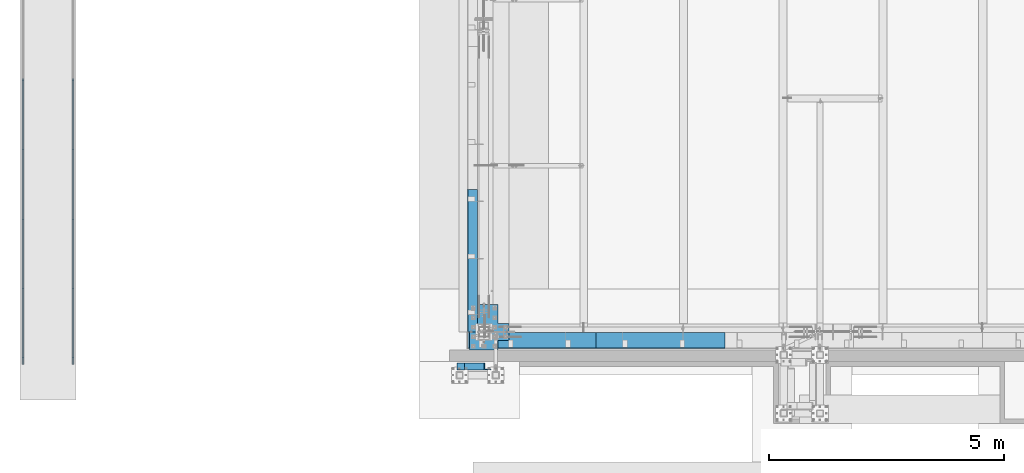
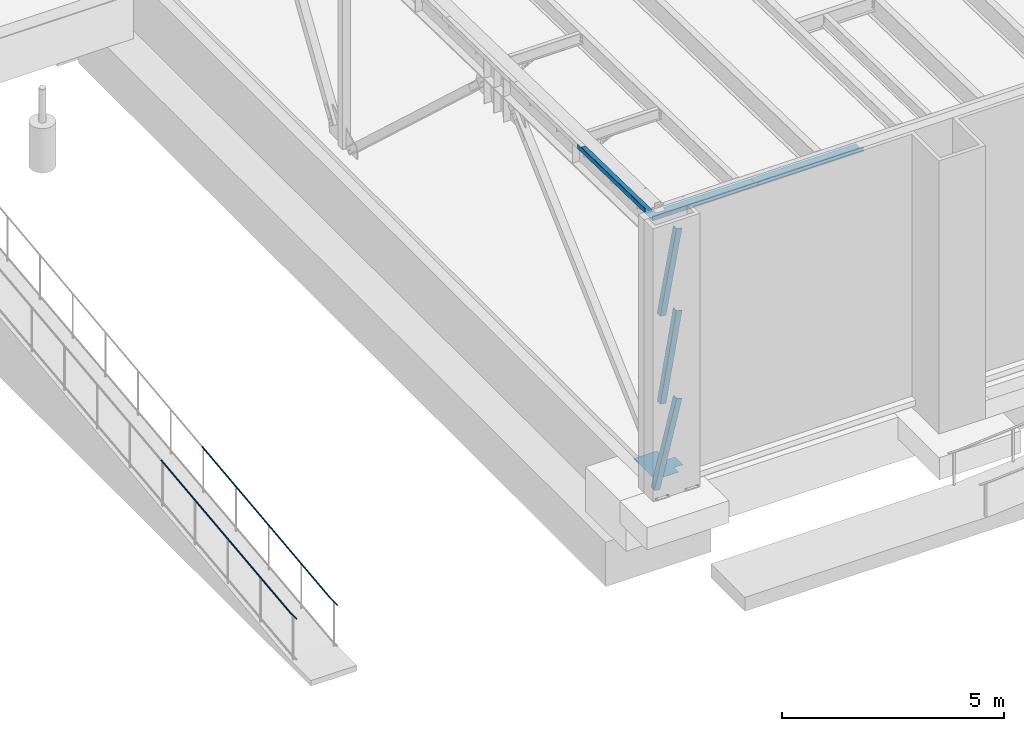
# One storey, part 1032 of 1763: 6 beams, 3 members, 6 elements without a shape of their own.
"""IFC2X3 building model written with IfcOpenShell, lengths in millimetres."""

from ifc_helpers import new_model, si_unit, frame, origin_with_axes, place, context, subcontext, project, spatial, faceted_brep, material, type_object, element, aggregate, save


model = new_model("IFC2X3")

# Units and contexts
model_context = context("Model", 3, precision=1e-05, world=origin_with_axes())
body_context = subcontext(model_context, "Body", "Model", "MODEL_VIEW")
ifc_project = project(units=[si_unit("LENGTHUNIT", "METRE", prefix="MILLI"), si_unit("AREAUNIT", "SQUARE_METRE"), si_unit("VOLUMEUNIT", "CUBIC_METRE"), si_unit("MASSUNIT", "GRAM", prefix="KILO"), si_unit("TIMEUNIT", "SECOND"), si_unit("PLANEANGLEUNIT", "RADIAN"), si_unit("SOLIDANGLEUNIT", "STERADIAN"), si_unit("THERMODYNAMICTEMPERATUREUNIT", "DEGREE_CELSIUS"), si_unit("LUMINOUSINTENSITYUNIT", "LUMEN")], contexts=[model_context])

# Site, building, storey
site_placement = place(None, origin_with_axes())
site = spatial("IfcSite", under=ifc_project, at=site_placement, CompositionType="ELEMENT")
building_placement = place(site_placement, origin_with_axes())
building = spatial("IfcBuilding", under=site, at=building_placement, Name="Undefined", CompositionType="ELEMENT")
storey_placement = place(building_placement, origin_with_axes())
storey = spatial("IfcBuildingStorey", under=building, at=storey_placement, Name="Undefined", CompositionType="ELEMENT", Elevation=0.0)

# Assembly, beam
assembly_1_placement = place(storey_placement, origin_with_axes())
assembly_1 = element("IfcElementAssembly", 1, at=assembly_1_placement, inside=storey, Name="GUARDRAIL", AssemblyPlace="NOTDEFINED", PredefinedType="RIGID_FRAME")
ifc_material_1 = material(Name="STEEL/A513")
beam_type_1 = type_object("IfcBeamType", PredefinedType="NOTDEFINED")
beam_1_placement = place(assembly_1_placement, frame((-97200.6527017878, -8312.29390356327, 5446.44809051835), z_axis=(1.0, 0.0, 0.0), x_axis=(0.0, -0.993473565260443, -0.114062593029902)))
beam_1 = element("IfcBeam", 2, at=beam_1_placement, type_object=beam_type_1, material=ifc_material_1, Name="GUARDRAIL", context=body_context, shape_type="Brep", body=[
    faceted_brep([(0.0, -19.0500000000029, 0.0), (0.0, -16.4977839420899, -9.52500000000146), (5827.65439591303, -16.4977647754886, -9.52499999999418), (5827.65439592143, -19.0499808333961, 0.0), (0.0, -9.52499999999418, -16.4977839420935), (5827.65439589009, -9.52498083339196, -16.4977839420899), (1.45519152283669e-11, 1.81898940354586e-12, -19.0499999999993), (5827.65439585875, 1.91666122191236e-05, -19.0500000000029), (0.0, 9.52499999999418, -16.4977839420935), (5827.65439582742, 9.52501916661731, -16.4977839420899), (0.0, 16.4977839420899, -9.52500000000146), (5827.65439580447, 16.4978031087139, -9.52499999999418), (0.0, 19.0500000000029, 0.0), (5827.65439579608, 19.0500191666215, 0.0), (0.0, 16.4977839420899, 9.52500000000146), (5827.65439580447, 16.4978031087139, 9.52499999999418), (0.0, 9.52499999999418, 16.4977839420935), (5827.65439582742, 9.52501916661731, 16.4977839420899), (1.45519152283669e-11, 1.81898940354586e-12, 19.0499999999993), (5827.65439585875, 1.91666122191236e-05, 19.0500000000029), (0.0, -9.52499999999418, 16.4977839420935), (5827.65439589009, -9.52498083339196, 16.4977839420899), (0.0, -16.4977839420899, 9.52500000000146), (5827.65439591303, -16.4977647754886, 9.52499999999418), (4.71409293822944e-08, -15.3669999999984, 0.0), (-1.81898940354586e-12, -13.3082123799541, 7.68349999999919), (5827.65439590254, -13.30819321335, 7.68349999999919), (5827.65439590931, -15.3669808333943, 0.0), (-3.63797880709171e-12, -7.68349999999919, 13.3082123799531), (5827.65439588403, -7.68348083339151, 13.3082123799541), (-1.81898940354586e-12, 0.0, 15.3669999999966), (5827.65439585875, 1.91666122191236e-05, 15.3669999999984), (-3.63797880709171e-12, 7.68349999999919, 13.3082123799531), (5827.65439583347, 7.68351916661686, 13.3082123799541), (-1.81898940354586e-12, 13.3082123799541, 7.68349999999919), (5827.65439581497, 13.3082315465745, 7.68349999999919), (4.71409293822944e-08, 15.3669999999984, 0.0), (5827.65439580819, 15.3670191666197, 0.0), (3.63797880709171e-12, 13.3082123799541, -7.68349999999737), (5827.65439581497, 13.3082315465745, -7.68349999999919), (3.63797880709171e-12, 7.68349999999919, -13.3082123799522), (5827.65439583347, 7.68351916661686, -13.3082123799541), (3.63797880709171e-12, 0.0, -15.3669999999956), (5827.65439585875, 1.91666122191236e-05, -15.3669999999984), (3.63797880709171e-12, -7.68349999999919, -13.3082123799522), (5827.65439588403, -7.68348083339151, -13.3082123799541), (3.63797880709171e-12, -13.3082123799541, -7.68349999999737), (5827.65439590254, -13.30819321335, -7.68349999999919), (5828.30042607954, -16.497764773364, -9.52499999999418), (5828.15439592142, -19.0499808317518, 0.0), (5828.69938789095, -9.52498082995589, -16.4977839420899), (5829.24437986047, 1.91718418136588e-05, -19.0500000000029), (5829.78937183, 9.52501917363952, -16.4977839420899), (5830.18833364141, 16.4978031170485, -9.52499999999418), (5830.33436379952, 19.0500191754363, 0.0), (5830.18833364141, 16.4978031170485, 9.52499999999418), (5829.78937183, 9.52501917363952, 16.4977839420899), (5829.24437986047, 1.91718418136588e-05, 19.0500000000029), (5828.69938789095, -9.52498082995589, 16.4977839420899), (5828.30042607954, -16.497764773364, 9.52499999999418), (5828.48292381052, -13.3081932106252, 7.68349999999919), (5828.36512614964, -15.3669808310569, 0.0), (5828.80475300506, -7.68348082960711, 13.3082123799541), (5829.24437986047, 1.91718418136588e-05, 15.3669999999984), (5829.68400671589, 7.68351917329164, 13.3082123799541), (5830.00583591043, 13.3082315543088, 7.68349999999919), (5830.12363357131, 15.3670191747406, 0.0), (5830.00583591043, 13.3082315543088, -7.68349999999919), (5829.68400671589, 7.68351917329164, -13.3082123799541), (5829.24437986047, 1.91718418136588e-05, -15.3669999999984), (5828.80475300506, -7.68348082960711, -13.3082123799541), (5828.48292381052, -13.3081932106252, -7.68349999999919), (5828.94224011997, -16.5714513634848, -9.52499999999418), (5828.65113281832, -19.1070111330755, 0.0), (5829.73756005851, -9.64417324733404, -16.4977839420899), (5830.82398729871, -0.181335361592573, -19.0500000000029), (5831.9104145389, 9.28150252414889, -16.4977839420899), (5832.70573447745, 16.2087806402988, -9.52499999999418), (5832.9968417791, 18.7443404098904, 0.0), (5832.70573447745, 16.2087806402988, 9.52499999999418), (5831.9104145389, 9.28150252414889, 16.4977839420899), (5830.82398729871, -0.181335361592573, 19.0500000000029), (5829.73756005851, -9.64417324733404, 16.4977839420899), (5828.94224011997, -16.5714513634848, 9.52499999999418), (5829.30604457453, -13.4026956031184, 7.68349999999919), (5829.07121801786, -15.4480471505885, 0.0), (5829.94760265829, -7.81469125609055, 13.3082123799541), (5830.82398729871, -0.181335361592573, 15.3669999999984), (5831.70037193913, 7.4520205329045, 13.3082123799541), (5832.3419300229, 13.0400248799333, 7.68349999999919), (5832.57675657956, 15.0853764274034, 0.0), (5832.3419300229, 13.0400248799333, -7.68349999999919), (5831.70037193913, 7.4520205329045, -13.3082123799541), (5830.82398729871, -0.181335361592573, -15.3669999999984), (5829.94760265829, -7.81469125609055, -13.3082123799541), (5829.30604457453, -13.4026956031184, -7.68349999999919), (6130.1732509878, -51.1557462392875, -9.52499999999418), (6129.88214368616, -53.6913060088782, 0.0), (6130.96857092635, -44.2284681231367, -16.4977839420899), (6132.05499816655, -34.7656302373944, -19.0500000000029), (6133.14142540674, -25.3027923516547, -16.4977839420899), (6133.93674534529, -18.3755142355039, -9.52499999999418), (6134.22785264694, -15.8399544659133, 0.0), (6133.93674534529, -18.3755142355039, 9.52499999999418), (6133.14142540674, -25.3027923516547, 16.4977839420899), (6132.05499816655, -34.7656302373944, 19.0500000000029), (6130.96857092635, -44.2284681231367, 16.4977839420899), (6130.1732509878, -51.1557462392875, 9.52499999999418), (6130.53705544236, -47.9869904789211, 7.68349999999919), (6130.3022288857, -50.0323420263921, 0.0), (6131.17861352613, -42.3989861318933, 13.3082123799541), (6132.05499816655, -34.7656302373944, 15.3669999999984), (6132.93138280697, -27.1322743428982, 13.3082123799541), (6133.57294089074, -21.5442699958694, 7.68349999999919), (6133.8077674474, -19.4989184483993, 0.0), (6133.57294089074, -21.5442699958694, -7.68349999999919), (6132.93138280697, -27.1322743428982, -13.3082123799541), (6132.05499816655, -34.7656302373944, -15.3669999999984), (6131.17861352613, -42.3989861318933, -13.3082123799541), (6130.53705544236, -47.9869904789211, -7.68349999999919)], [[[0, 1, 2, 3]], [[1, 4, 5, 2]], [[4, 6, 7, 5]], [[6, 8, 9, 7]], [[8, 10, 11, 9]], [[10, 12, 13, 11]], [[12, 14, 15, 13]], [[14, 16, 17, 15]], [[16, 18, 19, 17]], [[18, 20, 21, 19]], [[20, 22, 23, 21]], [[22, 0, 3, 23]], [[24, 25, 26, 27]], [[25, 28, 29, 26]], [[28, 30, 31, 29]], [[30, 32, 33, 31]], [[32, 34, 35, 33]], [[34, 36, 37, 35]], [[36, 38, 39, 37]], [[38, 40, 41, 39]], [[40, 42, 43, 41]], [[42, 44, 45, 43]], [[44, 46, 47, 45]], [[46, 24, 27, 47]], [[22, 20, 18, 16, 14, 12, 10, 8, 6, 4, 1, 0], [46, 44, 42, 40, 38, 36, 34, 32, 30, 28, 25, 24]], [[3, 2, 48, 49]], [[2, 5, 50, 48]], [[5, 7, 51, 50]], [[7, 9, 52, 51]], [[9, 11, 53, 52]], [[11, 13, 54, 53]], [[13, 15, 55, 54]], [[15, 17, 56, 55]], [[17, 19, 57, 56]], [[19, 21, 58, 57]], [[21, 23, 59, 58]], [[23, 3, 49, 59]], [[27, 26, 60, 61]], [[26, 29, 62, 60]], [[29, 31, 63, 62]], [[31, 33, 64, 63]], [[33, 35, 65, 64]], [[35, 37, 66, 65]], [[37, 39, 67, 66]], [[39, 41, 68, 67]], [[41, 43, 69, 68]], [[43, 45, 70, 69]], [[45, 47, 71, 70]], [[47, 27, 61, 71]], [[49, 48, 72, 73]], [[48, 50, 74, 72]], [[50, 51, 75, 74]], [[51, 52, 76, 75]], [[52, 53, 77, 76]], [[53, 54, 78, 77]], [[54, 55, 79, 78]], [[55, 56, 80, 79]], [[56, 57, 81, 80]], [[57, 58, 82, 81]], [[58, 59, 83, 82]], [[59, 49, 73, 83]], [[61, 60, 84, 85]], [[60, 62, 86, 84]], [[62, 63, 87, 86]], [[63, 64, 88, 87]], [[64, 65, 89, 88]], [[65, 66, 90, 89]], [[66, 67, 91, 90]], [[67, 68, 92, 91]], [[68, 69, 93, 92]], [[69, 70, 94, 93]], [[70, 71, 95, 94]], [[71, 61, 85, 95]], [[73, 72, 96, 97]], [[72, 74, 98, 96]], [[74, 75, 99, 98]], [[75, 76, 100, 99]], [[76, 77, 101, 100]], [[77, 78, 102, 101]], [[78, 79, 103, 102]], [[79, 80, 104, 103]], [[80, 81, 105, 104]], [[81, 82, 106, 105]], [[82, 83, 107, 106]], [[83, 73, 97, 107]], [[85, 84, 108, 109]], [[84, 86, 110, 108]], [[86, 87, 111, 110]], [[87, 88, 112, 111]], [[88, 89, 113, 112]], [[89, 90, 114, 113]], [[90, 91, 115, 114]], [[91, 92, 116, 115]], [[92, 93, 117, 116]], [[93, 94, 118, 117]], [[94, 95, 119, 118]], [[95, 85, 109, 119]], [[98, 99, 100, 101, 102, 103, 104, 105, 106, 107, 97, 96], [110, 111, 112, 113, 114, 115, 116, 117, 118, 119, 109, 108]]]),
])
aggregate(assembly_1, [beam_1])

assembly_2_placement = place(storey_placement, origin_with_axes())
assembly_2 = element("IfcElementAssembly", 3, at=assembly_2_placement, inside=storey, Name="GUARDRAIL", AssemblyPlace="NOTDEFINED", PredefinedType="RIGID_FRAME")
beam_2_placement = place(assembly_2_placement, frame((-96133.8527017878, -8312.29390356327, 5446.44809051835), z_axis=(1.0, 0.0, 0.0), x_axis=(0.0, -0.993473565260443, -0.114062593029902)))
beam_2 = element("IfcBeam", 4, at=beam_2_placement, type_object=beam_type_1, material=ifc_material_1, Name="GUARDRAIL", context=body_context, shape_type="Brep", body=[
    faceted_brep([(0.0, -19.0500000000029, 0.0), (0.0, -16.4977839420899, -9.52500000000146), (5827.65439591303, -16.4977647754886, -9.52499999999418), (5827.65439592143, -19.0499808333961, 0.0), (0.0, -9.52499999999418, -16.4977839420935), (5827.65439589009, -9.52498083339196, -16.4977839420899), (1.45519152283669e-11, 1.81898940354586e-12, -19.0499999999993), (5827.65439585875, 1.91666122191236e-05, -19.0500000000029), (0.0, 9.52499999999418, -16.4977839420935), (5827.65439582742, 9.52501916661731, -16.4977839420899), (0.0, 16.4977839420899, -9.52500000000146), (5827.65439580447, 16.4978031087139, -9.52499999999418), (0.0, 19.0500000000029, 0.0), (5827.65439579608, 19.0500191666215, 0.0), (0.0, 16.4977839420899, 9.52500000000146), (5827.65439580447, 16.4978031087139, 9.52499999999418), (0.0, 9.52499999999418, 16.4977839420935), (5827.65439582742, 9.52501916661731, 16.4977839420899), (1.45519152283669e-11, 1.81898940354586e-12, 19.0499999999993), (5827.65439585875, 1.91666122191236e-05, 19.0500000000029), (0.0, -9.52499999999418, 16.4977839420935), (5827.65439589009, -9.52498083339196, 16.4977839420899), (0.0, -16.4977839420899, 9.52500000000146), (5827.65439591303, -16.4977647754886, 9.52499999999418), (4.71409293822944e-08, -15.3669999999984, 0.0), (-1.81898940354586e-12, -13.3082123799541, 7.68349999999919), (5827.65439590254, -13.30819321335, 7.68349999999919), (5827.65439590931, -15.3669808333943, 0.0), (-3.63797880709171e-12, -7.68349999999919, 13.3082123799531), (5827.65439588403, -7.68348083339151, 13.3082123799541), (-1.81898940354586e-12, 0.0, 15.3669999999966), (5827.65439585875, 1.91666122191236e-05, 15.3669999999984), (-3.63797880709171e-12, 7.68349999999919, 13.3082123799531), (5827.65439583347, 7.68351916661686, 13.3082123799541), (-1.81898940354586e-12, 13.3082123799541, 7.68349999999919), (5827.65439581497, 13.3082315465745, 7.68349999999919), (4.71409293822944e-08, 15.3669999999984, 0.0), (5827.65439580819, 15.3670191666197, 0.0), (3.63797880709171e-12, 13.3082123799541, -7.68349999999737), (5827.65439581497, 13.3082315465745, -7.68349999999919), (3.63797880709171e-12, 7.68349999999919, -13.3082123799522), (5827.65439583347, 7.68351916661686, -13.3082123799541), (3.63797880709171e-12, 0.0, -15.3669999999956), (5827.65439585875, 1.91666122191236e-05, -15.3669999999984), (3.63797880709171e-12, -7.68349999999919, -13.3082123799522), (5827.65439588403, -7.68348083339151, -13.3082123799541), (3.63797880709171e-12, -13.3082123799541, -7.68349999999737), (5827.65439590254, -13.30819321335, -7.68349999999919), (5828.30042607954, -16.497764773364, -9.52499999999418), (5828.15439592142, -19.0499808317518, 0.0), (5828.69938789095, -9.52498082995589, -16.4977839420899), (5829.24437986047, 1.91718418136588e-05, -19.0500000000029), (5829.78937183, 9.52501917363952, -16.4977839420899), (5830.18833364141, 16.4978031170485, -9.52499999999418), (5830.33436379952, 19.0500191754363, 0.0), (5830.18833364141, 16.4978031170485, 9.52499999999418), (5829.78937183, 9.52501917363952, 16.4977839420899), (5829.24437986047, 1.91718418136588e-05, 19.0500000000029), (5828.69938789095, -9.52498082995589, 16.4977839420899), (5828.30042607954, -16.497764773364, 9.52499999999418), (5828.48292381052, -13.3081932106252, 7.68349999999919), (5828.36512614964, -15.3669808310569, 0.0), (5828.80475300506, -7.68348082960711, 13.3082123799541), (5829.24437986047, 1.91718418136588e-05, 15.3669999999984), (5829.68400671589, 7.68351917329164, 13.3082123799541), (5830.00583591043, 13.3082315543088, 7.68349999999919), (5830.12363357131, 15.3670191747406, 0.0), (5830.00583591043, 13.3082315543088, -7.68349999999919), (5829.68400671589, 7.68351917329164, -13.3082123799541), (5829.24437986047, 1.91718418136588e-05, -15.3669999999984), (5828.80475300506, -7.68348082960711, -13.3082123799541), (5828.48292381052, -13.3081932106252, -7.68349999999919), (5828.94224011997, -16.5714513634848, -9.52499999999418), (5828.65113281832, -19.1070111330755, 0.0), (5829.73756005851, -9.64417324733404, -16.4977839420899), (5830.82398729871, -0.181335361592573, -19.0500000000029), (5831.9104145389, 9.28150252414889, -16.4977839420899), (5832.70573447745, 16.2087806402988, -9.52499999999418), (5832.9968417791, 18.7443404098904, 0.0), (5832.70573447745, 16.2087806402988, 9.52499999999418), (5831.9104145389, 9.28150252414889, 16.4977839420899), (5830.82398729871, -0.181335361592573, 19.0500000000029), (5829.73756005851, -9.64417324733404, 16.4977839420899), (5828.94224011997, -16.5714513634848, 9.52499999999418), (5829.30604457453, -13.4026956031184, 7.68349999999919), (5829.07121801786, -15.4480471505885, 0.0), (5829.94760265829, -7.81469125609055, 13.3082123799541), (5830.82398729871, -0.181335361592573, 15.3669999999984), (5831.70037193913, 7.4520205329045, 13.3082123799541), (5832.3419300229, 13.0400248799333, 7.68349999999919), (5832.57675657956, 15.0853764274034, 0.0), (5832.3419300229, 13.0400248799333, -7.68349999999919), (5831.70037193913, 7.4520205329045, -13.3082123799541), (5830.82398729871, -0.181335361592573, -15.3669999999984), (5829.94760265829, -7.81469125609055, -13.3082123799541), (5829.30604457453, -13.4026956031184, -7.68349999999919), (6130.1732509878, -51.1557462392875, -9.52499999999418), (6129.88214368616, -53.6913060088782, 0.0), (6130.96857092635, -44.2284681231367, -16.4977839420899), (6132.05499816655, -34.7656302373944, -19.0500000000029), (6133.14142540674, -25.3027923516547, -16.4977839420899), (6133.93674534529, -18.3755142355039, -9.52499999999418), (6134.22785264694, -15.8399544659133, 0.0), (6133.93674534529, -18.3755142355039, 9.52499999999418), (6133.14142540674, -25.3027923516547, 16.4977839420899), (6132.05499816655, -34.7656302373944, 19.0500000000029), (6130.96857092635, -44.2284681231367, 16.4977839420899), (6130.1732509878, -51.1557462392875, 9.52499999999418), (6130.53705544236, -47.9869904789211, 7.68349999999919), (6130.3022288857, -50.0323420263921, 0.0), (6131.17861352613, -42.3989861318933, 13.3082123799541), (6132.05499816655, -34.7656302373944, 15.3669999999984), (6132.93138280697, -27.1322743428982, 13.3082123799541), (6133.57294089074, -21.5442699958694, 7.68349999999919), (6133.8077674474, -19.4989184483993, 0.0), (6133.57294089074, -21.5442699958694, -7.68349999999919), (6132.93138280697, -27.1322743428982, -13.3082123799541), (6132.05499816655, -34.7656302373944, -15.3669999999984), (6131.17861352613, -42.3989861318933, -13.3082123799541), (6130.53705544236, -47.9869904789211, -7.68349999999919)], [[[0, 1, 2, 3]], [[1, 4, 5, 2]], [[4, 6, 7, 5]], [[6, 8, 9, 7]], [[8, 10, 11, 9]], [[10, 12, 13, 11]], [[12, 14, 15, 13]], [[14, 16, 17, 15]], [[16, 18, 19, 17]], [[18, 20, 21, 19]], [[20, 22, 23, 21]], [[22, 0, 3, 23]], [[24, 25, 26, 27]], [[25, 28, 29, 26]], [[28, 30, 31, 29]], [[30, 32, 33, 31]], [[32, 34, 35, 33]], [[34, 36, 37, 35]], [[36, 38, 39, 37]], [[38, 40, 41, 39]], [[40, 42, 43, 41]], [[42, 44, 45, 43]], [[44, 46, 47, 45]], [[46, 24, 27, 47]], [[22, 20, 18, 16, 14, 12, 10, 8, 6, 4, 1, 0], [46, 44, 42, 40, 38, 36, 34, 32, 30, 28, 25, 24]], [[3, 2, 48, 49]], [[2, 5, 50, 48]], [[5, 7, 51, 50]], [[7, 9, 52, 51]], [[9, 11, 53, 52]], [[11, 13, 54, 53]], [[13, 15, 55, 54]], [[15, 17, 56, 55]], [[17, 19, 57, 56]], [[19, 21, 58, 57]], [[21, 23, 59, 58]], [[23, 3, 49, 59]], [[27, 26, 60, 61]], [[26, 29, 62, 60]], [[29, 31, 63, 62]], [[31, 33, 64, 63]], [[33, 35, 65, 64]], [[35, 37, 66, 65]], [[37, 39, 67, 66]], [[39, 41, 68, 67]], [[41, 43, 69, 68]], [[43, 45, 70, 69]], [[45, 47, 71, 70]], [[47, 27, 61, 71]], [[49, 48, 72, 73]], [[48, 50, 74, 72]], [[50, 51, 75, 74]], [[51, 52, 76, 75]], [[52, 53, 77, 76]], [[53, 54, 78, 77]], [[54, 55, 79, 78]], [[55, 56, 80, 79]], [[56, 57, 81, 80]], [[57, 58, 82, 81]], [[58, 59, 83, 82]], [[59, 49, 73, 83]], [[61, 60, 84, 85]], [[60, 62, 86, 84]], [[62, 63, 87, 86]], [[63, 64, 88, 87]], [[64, 65, 89, 88]], [[65, 66, 90, 89]], [[66, 67, 91, 90]], [[67, 68, 92, 91]], [[68, 69, 93, 92]], [[69, 70, 94, 93]], [[70, 71, 95, 94]], [[71, 61, 85, 95]], [[73, 72, 96, 97]], [[72, 74, 98, 96]], [[74, 75, 99, 98]], [[75, 76, 100, 99]], [[76, 77, 101, 100]], [[77, 78, 102, 101]], [[78, 79, 103, 102]], [[79, 80, 104, 103]], [[80, 81, 105, 104]], [[81, 82, 106, 105]], [[82, 83, 107, 106]], [[83, 73, 97, 107]], [[85, 84, 108, 109]], [[84, 86, 110, 108]], [[86, 87, 111, 110]], [[87, 88, 112, 111]], [[88, 89, 113, 112]], [[89, 90, 114, 113]], [[90, 91, 115, 114]], [[91, 92, 116, 115]], [[92, 93, 117, 116]], [[93, 94, 118, 117]], [[94, 95, 119, 118]], [[95, 85, 109, 119]], [[98, 99, 100, 101, 102, 103, 104, 105, 106, 107, 97, 96], [110, 111, 112, 113, 114, 115, 116, 117, 118, 119, 109, 108]]]),
])
aggregate(assembly_2, [beam_2])

# Assembly, members
assembly_3_placement = place(storey_placement, origin_with_axes())
assembly_3 = element("IfcElementAssembly", 5, at=assembly_3_placement, inside=storey, Name="FRAME", AssemblyPlace="NOTDEFINED", PredefinedType="RIGID_FRAME")
ifc_material_2 = material(Name="STEEL/A36")
member_type = type_object("IfcMemberType", Name="L6X6X7/8", PredefinedType="NOTDEFINED")
member_1_placement = place(assembly_3_placement, frame((-87893.5063181838, -14449.425, 5067.3), z_axis=(0.970049362251247, 0.0, -0.242907873062915), x_axis=(0.242907873062914, 0.0, 0.970049362251247)))
member_1 = element("IfcMember", 6, at=member_1_placement, type_object=member_type, material=ifc_material_2, Name="V. BRACE", ObjectType="L6X6X7/8", context=body_context, shape_type="Brep", body=[
    faceted_brep([(60.7931588511128, 76.2000000000007, -76.1999999999534), (58.5843248765377, 76.2000000000007, 76.2000000000553), (2454.77198625823, 76.2000000000007, 76.2000000021071), (2454.77198625822, 76.2000000000007, -76.1999999979016), (58.5843248765377, 53.9750000000004, 76.2000000000553), (2454.77198625823, 53.9750000000004, 76.2000000021071), (60.4710372298214, 53.9750000000004, -53.9749999999476), (2454.77198625822, 53.9750000000004, -53.9749999978958), (60.4710372298214, -76.2000000000007, -53.9749999999476), (2454.77198625822, -76.2000000000007, -53.9749999978958), (60.7931588511128, -76.2000000000007, -76.1999999999534), (2454.77198625822, -76.2000000000007, -76.1999999979016)], [[[0, 1, 2, 3]], [[1, 4, 5, 2]], [[4, 6, 7, 5]], [[6, 8, 9, 7]], [[8, 10, 11, 9]], [[10, 0, 3, 11]], [[5, 7, 9, 11, 3, 2]], [[10, 8, 6, 4, 1, 0]]]),
])
member_2_placement = place(assembly_3_placement, frame((-87717.4606184991, -14449.425, 9867.9), z_axis=(0.983225526923755, 0.0, -0.182393977985856), x_axis=(0.182393977985856, 0.0, 0.983225526923755)))
member_2 = element("IfcMember", 7, at=member_2_placement, type_object=member_type, material=ifc_material_2, Name="V. BRACE", ObjectType="L6X6X7/8", context=body_context, shape_type="Brep", body=[
    faceted_brep([(9.09494701772928e-13, 76.2000000000007, -76.2000000000844), (0.0, 76.2000000000007, 76.2000000000771), (2299.16732010794, 76.2000000000007, 76.2000000008775), (2299.16732010795, 76.2000000000007, -76.199999999284), (0.0, 53.9750000000004, 76.2000000000771), (2299.16732010794, 53.9750000000004, 76.2000000008775), (1.81898940354586e-12, 53.9750000000004, -53.9750000000604), (2299.16732010795, 53.9750000000004, -53.97499999926), (1.81898940354586e-12, -76.2000000000007, -53.9750000000604), (2299.16732010795, -76.2000000000007, -53.97499999926), (9.09494701772928e-13, -76.2000000000007, -76.2000000000844), (2299.16732010795, -76.2000000000007, -76.199999999284)], [[[0, 1, 2, 3]], [[1, 4, 5, 2]], [[4, 6, 7, 5]], [[6, 8, 9, 7]], [[8, 10, 11, 9]], [[10, 0, 3, 11]], [[5, 7, 9, 11, 3, 2]], [[10, 8, 6, 4, 1, 0]]]),
])
member_3_placement = place(assembly_3_placement, frame((-87717.2446473739, -14449.425, 7448.55), z_axis=(0.985337026870794, 0.0, -0.170619293977627), x_axis=(0.170619293977628, 0.0, 0.985337026870794)))
member_3 = element("IfcMember", 8, at=member_3_placement, type_object=member_type, material=ifc_material_2, Name="V. BRACE", ObjectType="L6X6X7/8", context=body_context, shape_type="Brep", body=[
    faceted_brep([(9.09494701772928e-13, 76.2000000000007, -76.2000000000844), (0.0, 76.2000000000007, 76.2000000000771), (2455.35277151341, 76.2000000000007, 76.2000000014268), (2455.35277151334, 76.2000000000007, -76.199999998742), (0.0, 53.9750000000004, 76.2000000000771), (2455.35277151341, 53.9750000000004, 76.2000000014268), (1.81898940354586e-12, 53.9750000000004, -53.9750000000604), (2455.35277151335, 53.9750000000004, -53.974999998718), (1.81898940354586e-12, -76.2000000000007, -53.9750000000604), (2455.35277151335, -76.2000000000007, -53.974999998718), (9.09494701772928e-13, -76.2000000000007, -76.2000000000844), (2455.35277151334, -76.2000000000007, -76.199999998742)], [[[0, 1, 2, 3]], [[1, 4, 5, 2]], [[4, 6, 7, 5]], [[6, 8, 9, 7]], [[8, 10, 11, 9]], [[10, 0, 3, 11]], [[5, 7, 9, 11, 3, 2]], [[10, 8, 6, 4, 1, 0]]]),
])
aggregate(assembly_3, [member_1, member_2, member_3])

# Assembly, beams
assembly_4_placement = place(storey_placement, origin_with_axes())
assembly_4 = element("IfcElementAssembly", 9, at=assembly_4_placement, inside=storey, Name="BEAM", AssemblyPlace="NOTDEFINED", PredefinedType="RIGID_FRAME")
beam_type_2 = type_object("IfcBeamType", PredefinedType="NOTDEFINED")
beam_3_placement = place(assembly_4_placement, frame((-86353.0872736983, -13728.6998186171, 12207.875), z_axis=(-1.0, 0.0, 0.0), x_axis=(0.0, -1.0, 0.0)))
beam_3 = element("IfcBeam", 10, at=beam_3_placement, type_object=beam_type_2, material=ifc_material_2, Name="BENT_PLATE", context=body_context, shape_type="Brep", body=[
    faceted_brep([(101.600181382933, -3.17499999999927, 908.050009155297), (101.600181382933, 3.17499999999927, 908.050009155297), (0.0, 3.17499999999927, 908.050009155297), (0.0, -3.17499999999927, 908.050009155297), (101.600181382926, -3.17499999999927, 1136.65000000002), (101.600181382926, 3.17499999999927, 1136.65000000002), (0.0, -3.17499999999927, 1136.65000000007), (0.0, 3.17499999999927, 1136.65000000007), (336.549987792969, -3.17499999999927, 1371.60000000001), (336.549987792969, -3.17499999999927, -1371.60000000001), (336.549987792969, 123.825000000001, -1371.60000000001), (336.549987792969, 123.825000000001, 1371.60000000001), (330.19998779297, 3.17499999999927, 1371.60000000001), (-2.91038304567337e-11, 3.17499999963184, 1371.60000000395), (-2.91038304567337e-11, -3.17500000036489, 1371.60000000395), (330.19998779297, 123.825000000001, 1371.60000000001), (330.19998779297, 3.17499999999927, -1371.60000000001), (330.19998779297, 123.825000000001, -1371.60000000001), (2.91038304567337e-11, -3.17499999963729, -1371.60000000396), (2.91038304567337e-11, 3.17500000035943, -1371.60000000396)], [[[0, 1, 2, 3]], [[4, 5, 1, 0]], [[6, 7, 5, 4]], [[8, 9, 10, 11]], [[12, 13, 14, 8, 11, 15]], [[16, 12, 15, 17]], [[11, 10, 17, 15]], [[9, 18, 19, 16, 17, 10]], [[19, 18, 3, 2]], [[13, 12, 16, 19, 2, 1, 5, 7]], [[14, 13, 7, 6]], [[3, 18, 9, 8, 14, 6, 4, 0]]]),
])
beam_4_placement = place(assembly_4_placement, frame((-83609.8872736983, -13728.6998186171, 12207.875), z_axis=(-1.0, 0.0, 0.0), x_axis=(0.0, -1.0, 0.0)))
beam_4 = element("IfcBeam", 11, at=beam_4_placement, type_object=beam_type_2, material=ifc_material_2, Name="BENT_PLATE", context=body_context, shape_type="Brep", body=[
    faceted_brep([(2.91038304567337e-11, -3.17499999963729, -1371.60000000396), (-2.91038304567337e-11, -3.17500000036489, 1371.60000000395), (-2.91038304567337e-11, 3.17499999963184, 1371.60000000395), (2.91038304567337e-11, 3.17500000035943, -1371.60000000396), (330.19998779297, 3.17499999999927, 1371.60000000001), (330.19998779297, 3.17499999999927, -1371.60000000001), (336.549987792969, -3.17499999999927, -1371.60000000001), (336.549987792969, -3.17499999999927, 1371.60000000001), (330.19998779297, 123.825000000001, 1371.60000000001), (330.19998779297, 123.825000000001, -1371.60000000001), (336.549987792969, 123.825000000001, 1371.60000000001), (336.549987792969, 123.825000000001, -1371.60000000001)], [[[0, 1, 2, 3]], [[3, 2, 4, 5]], [[1, 0, 6, 7]], [[5, 4, 8, 9]], [[4, 2, 1, 7, 10, 8]], [[7, 6, 11, 10]], [[6, 0, 3, 5, 9, 11]], [[10, 11, 9, 8]]]),
])
aggregate(assembly_4, [beam_3, beam_4])

# Assembly, beam
assembly_5_placement = place(storey_placement, origin_with_axes())
assembly_5 = element("IfcElementAssembly", 12, at=assembly_5_placement, inside=storey, Name="BEAM", AssemblyPlace="NOTDEFINED", PredefinedType="RIGID_FRAME")
beam_type_3 = type_object("IfcBeamType", PredefinedType="NOTDEFINED")
beam_5_placement = place(assembly_5_placement, frame((-87516.7242736983, -12198.5902101101, 12176.1528426981), z_axis=(0.0, -0.999781542838788, 0.0209013539966307), x_axis=(-1.0, 0.0, 0.0)))
beam_5 = element("IfcBeam", 13, at=beam_5_placement, type_object=beam_type_3, material=ifc_material_2, Name="BENT_PLATE", context=body_context, shape_type="Brep", body=[
    faceted_brep([(0.0, -3.17499999999927, -1523.99999999999), (0.0, -3.17499999999927, 1524.0), (0.0, 3.17499999999927, 1524.0), (0.0, 3.17499999999927, -1523.99999999999), (207.962982177749, 3.17499999952452, 1524.00000000123), (207.96298217772, 3.17500000052678, -1524.00000000122), (201.612982177714, -3.17499999947904, -1524.00000000123), (201.612982177743, -3.1750000004813, 1524.00000000122), (207.962982177734, -123.82500358932, 1524.00000000118), (207.962982177734, -123.825003588276, -1524.00000000127), (201.612982177729, -123.82500358932, 1524.00000000118), (201.612982177729, -123.825003588276, -1524.00000000127)], [[[0, 1, 2, 3]], [[3, 2, 4, 5]], [[1, 0, 6, 7]], [[5, 4, 8, 9]], [[4, 2, 1, 7, 10, 8]], [[7, 6, 11, 10]], [[6, 0, 3, 5, 9, 11]], [[10, 11, 9, 8]]]),
])
aggregate(assembly_5, [beam_5])

assembly_6_placement = place(storey_placement, origin_with_axes())
assembly_6 = element("IfcElementAssembly", 14, at=assembly_6_placement, inside=storey, Name="TEMPLATE", AssemblyPlace="NOTDEFINED", PredefinedType="RIGID_FRAME")
beam_type_4 = type_object("IfcBeamType", PredefinedType="NOTDEFINED")
beam_6_placement = place(assembly_6_placement, frame((-87261.1372736983, -14097.0, 5083.17500000001), z_axis=(-1.0, 0.0, 0.0), x_axis=(0.0, 1.0, 0.0)))
beam_6 = element("IfcBeam", 15, at=beam_6_placement, type_object=beam_type_4, material=ifc_material_2, Name="TEMPLATE", context=body_context, shape_type="Brep", body=[
    faceted_brep([(558.800000000001, -3.17500000000018, -419.100000000006), (558.800000000001, 3.17500000000018, -419.100000000006), (558.800000000001, 3.17500000000018, -190.500000000015), (558.800000000001, -3.17500000000018, -190.500000000015), (965.200000000001, -3.17500000000018, -190.500000000015), (965.200000000001, 3.17500000000018, -190.500000000015), (203.200000000001, -3.17500000000018, -190.500000000015), (203.200000000001, 3.17500000000018, -190.500000000015), (203.200000000001, 3.17500000000018, -419.100000000006), (203.200000000001, -3.17500000000018, -419.100000000006), (0.0, -3.17500000000018, -190.500000000015), (0.0, 3.17500000000018, -190.500000000015), (0.0, -3.17500000000018, 419.100000000006), (0.0, 3.17500000000018, 419.100000000006), (965.200000000001, -3.17500000000018, 419.100000000006), (965.200000000001, 3.17500000000018, 419.100000000006)], [[[0, 1, 2, 3]], [[4, 3, 2, 5]], [[6, 7, 8, 9]], [[10, 11, 7, 6]], [[12, 13, 11, 10]], [[13, 12, 14, 15]], [[15, 14, 4, 5]], [[1, 8, 7, 11, 13, 15, 5, 2]], [[9, 8, 1, 0]], [[14, 12, 10, 6, 9, 0, 3, 4]]]),
])
aggregate(assembly_6, [beam_6])

save(model, "model.ifc")
